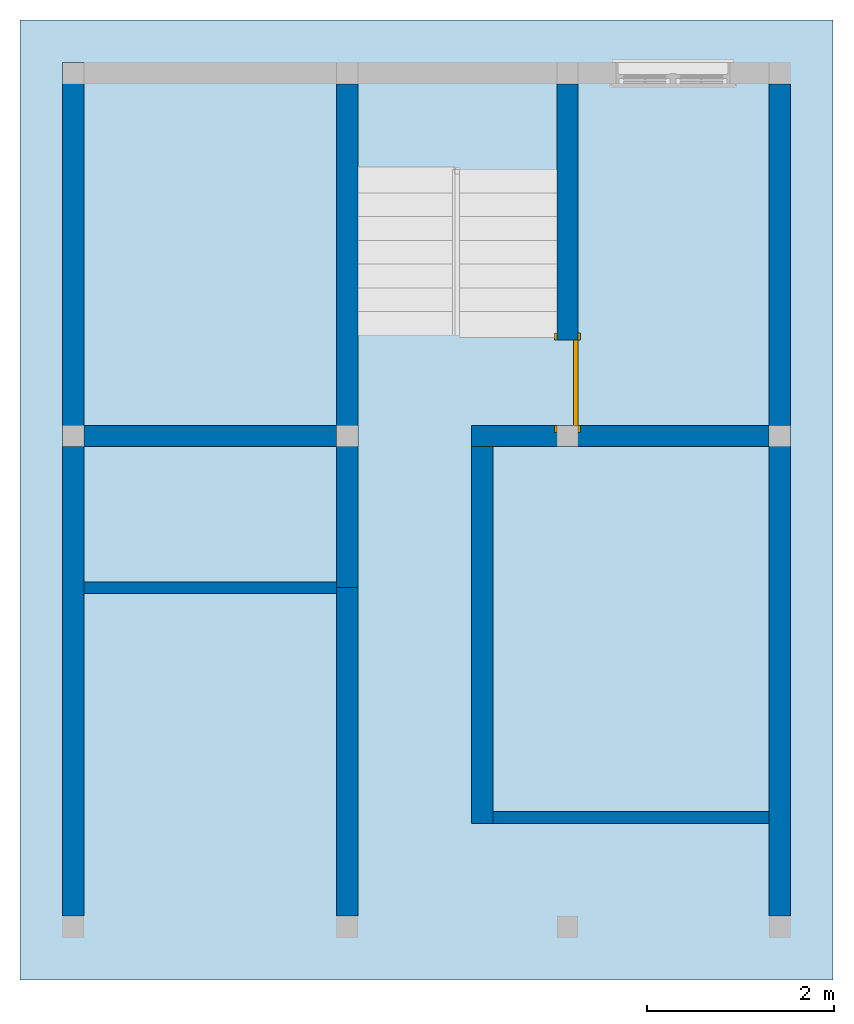
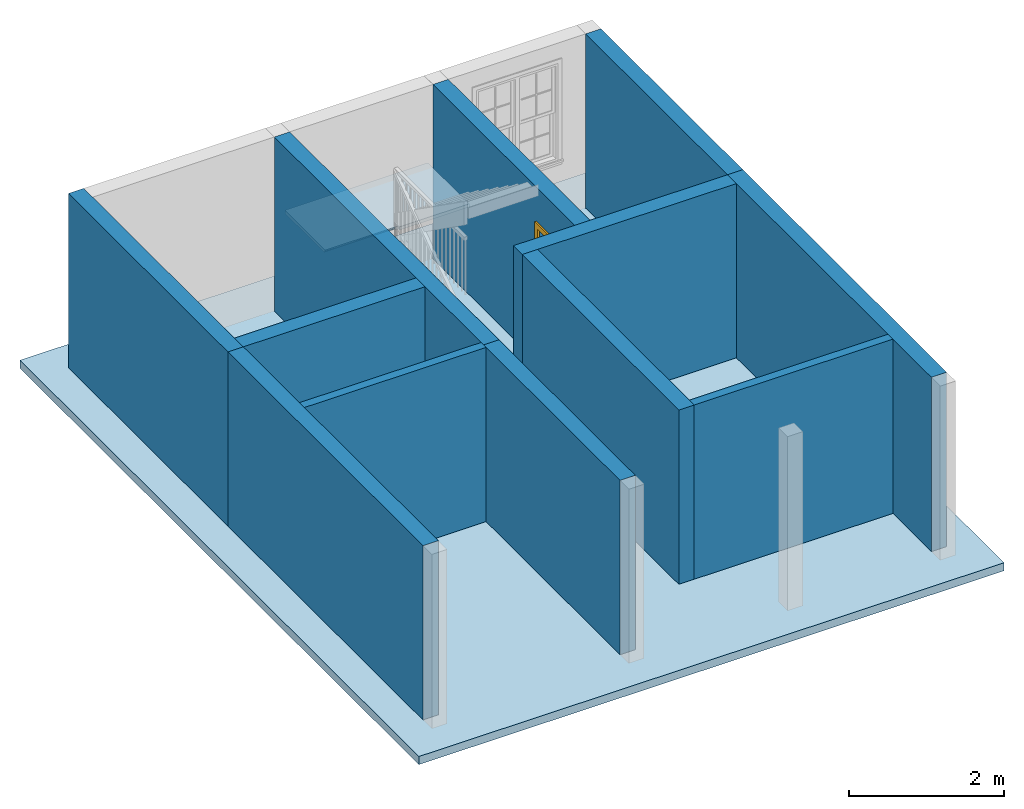
# One storey, part 2 of 6: 12 walls, 2 slabs, 1 door, 2 openings, 1 element without a shape of its own.
"""IFC2X3 building model written with IfcOpenShell, lengths in feet."""

from ifc_helpers import new_model, entity, si_unit, converted_unit, derived_unit, direction, frame, frame_2d, origin, origin_2d_with_axis, place, context, subcontext, project, spatial, polyline, rectangle, outline, extrude, clip, bounded_halfspace, faceted_brep, source, transform, mapped, material, material_list, layer, layer_set, layer_usage, type_object, type_shapes, element, fill, aggregate, save


model = new_model("IFC2X3")

# Units and contexts
model_context = context("Model", 3, precision=0.0001, world=origin(), true_north=direction((6.123031769111886e-17, 1.0)))
body_context = subcontext(model_context, "Body", "Model", "MODEL_VIEW")
ifc_project = project(units=[converted_unit("LENGTHUNIT", "FOOT", entity("IfcLengthMeasure", 0.3048), si_unit("LENGTHUNIT", "METRE"), dimensions=[1, 0, 0, 0, 0, 0, 0]), converted_unit("AREAUNIT", "SQUARE FOOT", entity("IfcAreaMeasure", 0.09290304), si_unit("AREAUNIT", "SQUARE_METRE"), dimensions=[2, 0, 0, 0, 0, 0, 0]), converted_unit("VOLUMEUNIT", "CUBIC FOOT", entity("IfcVolumeMeasure", 0.028316846592000004), si_unit("VOLUMEUNIT", "CUBIC_METRE"), dimensions=[3, 0, 0, 0, 0, 0, 0]), converted_unit("PLANEANGLEUNIT", "DEGREE", entity("IfcPlaneAngleMeasure", 0.017453292519943278), si_unit("PLANEANGLEUNIT", "RADIAN"), dimensions=[0, 0, 0, 0, 0, 0, 0]), si_unit("MASSUNIT", "GRAM", prefix="KILO"), derived_unit("MASSDENSITYUNIT", [(si_unit("MASSUNIT", "GRAM", prefix="KILO"), 1), (si_unit("LENGTHUNIT", "METRE"), -3)]), derived_unit("IONCONCENTRATIONUNIT", [(si_unit("MASSUNIT", "GRAM", prefix="KILO"), 1), (si_unit("LENGTHUNIT", "METRE"), -3)]), derived_unit("MOMENTOFINERTIAUNIT", [(si_unit("LENGTHUNIT", "METRE"), 4)]), si_unit("TIMEUNIT", "SECOND"), si_unit("FREQUENCYUNIT", "HERTZ"), si_unit("THERMODYNAMICTEMPERATUREUNIT", "DEGREE_CELSIUS"), derived_unit("THERMALTRANSMITTANCEUNIT", [(si_unit("MASSUNIT", "GRAM", prefix="KILO"), 1), (si_unit("THERMODYNAMICTEMPERATUREUNIT", "KELVIN"), -1), (si_unit("TIMEUNIT", "SECOND"), -3)]), derived_unit("THERMALCONDUCTANCEUNIT", [(si_unit("MASSUNIT", "GRAM", prefix="KILO"), 1), (si_unit("THERMODYNAMICTEMPERATUREUNIT", "KELVIN"), -1), (si_unit("TIMEUNIT", "SECOND"), -3), (si_unit("LENGTHUNIT", "METRE"), 1)]), derived_unit("VOLUMETRICFLOWRATEUNIT", [(si_unit("LENGTHUNIT", "METRE"), 3), (si_unit("TIMEUNIT", "SECOND"), -1)]), derived_unit("MASSFLOWRATEUNIT", [(si_unit("MASSUNIT", "GRAM", prefix="KILO"), 1), (si_unit("TIMEUNIT", "SECOND"), -1)]), derived_unit("ROTATIONALFREQUENCYUNIT", [(si_unit("TIMEUNIT", "SECOND"), -1)]), si_unit("ELECTRICCURRENTUNIT", "AMPERE"), si_unit("ELECTRICVOLTAGEUNIT", "VOLT"), si_unit("POWERUNIT", "WATT"), converted_unit("FORCEUNIT", "KIP", entity("IfcForceMeasure", 2.088543423315013e-05), si_unit("FORCEUNIT", "NEWTON"), dimensions=[1, 1, -2, 0, 0, 0, 0]), si_unit("ILLUMINANCEUNIT", "LUX"), si_unit("LUMINOUSFLUXUNIT", "LUMEN"), si_unit("LUMINOUSINTENSITYUNIT", "CANDELA"), si_unit("ENERGYUNIT", "JOULE"), derived_unit("USERDEFINED", [(si_unit("MASSUNIT", "GRAM", prefix="KILO"), -1), (si_unit("LENGTHUNIT", "METRE"), -2), (si_unit("TIMEUNIT", "SECOND"), 3), (si_unit("LUMINOUSFLUXUNIT", "LUMEN"), 1)]), derived_unit("USERDEFINED", [(si_unit("MASSUNIT", "GRAM", prefix="KILO"), 1), (si_unit("TIMEUNIT", "SECOND"), -3), (si_unit("LENGTHUNIT", "METRE"), 3), (si_unit("ELECTRICCURRENTUNIT", "AMPERE"), -2)]), derived_unit("SOUNDPOWERUNIT", [(si_unit("MASSUNIT", "GRAM", prefix="KILO"), 1), (si_unit("TIMEUNIT", "SECOND"), -3), (si_unit("LENGTHUNIT", "METRE"), 2)]), derived_unit("SOUNDPRESSUREUNIT", [(si_unit("MASSUNIT", "GRAM", prefix="KILO"), 1), (si_unit("LENGTHUNIT", "METRE"), -1), (si_unit("TIMEUNIT", "SECOND"), -2)]), derived_unit("LINEARVELOCITYUNIT", [(si_unit("LENGTHUNIT", "METRE"), 1), (si_unit("TIMEUNIT", "SECOND"), -1)]), si_unit("PRESSUREUNIT", "PASCAL"), derived_unit("USERDEFINED", [(si_unit("MASSUNIT", "GRAM", prefix="KILO"), 1), (si_unit("LENGTHUNIT", "METRE"), -2), (si_unit("TIMEUNIT", "SECOND"), -2)]), derived_unit("LINEARFORCEUNIT", [(si_unit("MASSUNIT", "GRAM", prefix="KILO"), 1), (si_unit("TIMEUNIT", "SECOND"), -2)]), derived_unit("PLANARFORCEUNIT", [(si_unit("MASSUNIT", "GRAM", prefix="KILO"), 1), (si_unit("LENGTHUNIT", "METRE"), -1), (si_unit("TIMEUNIT", "SECOND"), -2)]), derived_unit("SPECIFICHEATCAPACITYUNIT", [(si_unit("THERMODYNAMICTEMPERATUREUNIT", "KELVIN"), -1), (si_unit("LENGTHUNIT", "METRE"), 2), (si_unit("TIMEUNIT", "SECOND"), -2)]), derived_unit("HEATFLUXDENSITYUNIT", [(si_unit("MASSUNIT", "GRAM", prefix="KILO"), 1), (si_unit("TIMEUNIT", "SECOND"), -3)]), derived_unit("HEATINGVALUEUNIT", [(si_unit("LENGTHUNIT", "METRE"), 2), (si_unit("TIMEUNIT", "SECOND"), -2)]), derived_unit("VAPORPERMEABILITYUNIT", [(si_unit("LENGTHUNIT", "METRE"), -1), (si_unit("TIMEUNIT", "SECOND"), 1)]), derived_unit("DYNAMICVISCOSITYUNIT", [(si_unit("MASSUNIT", "GRAM", prefix="KILO"), 1), (si_unit("TIMEUNIT", "SECOND"), -1), (si_unit("LENGTHUNIT", "METRE"), -1)]), derived_unit("THERMALEXPANSIONCOEFFICIENTUNIT", [(si_unit("THERMODYNAMICTEMPERATUREUNIT", "KELVIN"), -1)]), derived_unit("MODULUSOFELASTICITYUNIT", [(si_unit("MASSUNIT", "GRAM", prefix="KILO"), 1), (si_unit("LENGTHUNIT", "METRE"), -1), (si_unit("TIMEUNIT", "SECOND"), -2)]), derived_unit("ISOTHERMALMOISTURECAPACITYUNIT", [(si_unit("LENGTHUNIT", "METRE"), 3), (si_unit("MASSUNIT", "GRAM", prefix="KILO"), -1)]), derived_unit("MOISTUREDIFFUSIVITYUNIT", [(si_unit("TIMEUNIT", "SECOND"), -1), (si_unit("LENGTHUNIT", "METRE"), 2)]), derived_unit("MASSPERLENGTHUNIT", [(si_unit("MASSUNIT", "GRAM", prefix="KILO"), 1), (si_unit("LENGTHUNIT", "METRE"), -1)]), derived_unit("THERMALRESISTANCEUNIT", [(si_unit("MASSUNIT", "GRAM", prefix="KILO"), -1), (si_unit("TIMEUNIT", "SECOND"), 3), (si_unit("THERMODYNAMICTEMPERATUREUNIT", "KELVIN"), 1)]), derived_unit("ACCELERATIONUNIT", [(si_unit("LENGTHUNIT", "METRE"), 1), (si_unit("TIMEUNIT", "SECOND"), -2)]), derived_unit("ANGULARVELOCITYUNIT", [(si_unit("TIMEUNIT", "SECOND"), -1), (si_unit("PLANEANGLEUNIT", "RADIAN"), 1)]), derived_unit("LINEARSTIFFNESSUNIT", [(si_unit("MASSUNIT", "GRAM", prefix="KILO"), 1), (si_unit("TIMEUNIT", "SECOND"), -2)]), derived_unit("WARPINGCONSTANTUNIT", [(si_unit("LENGTHUNIT", "METRE"), 6)]), derived_unit("LINEARMOMENTUNIT", [(si_unit("MASSUNIT", "GRAM", prefix="KILO"), 1), (si_unit("LENGTHUNIT", "METRE"), 1), (si_unit("TIMEUNIT", "SECOND"), -2)]), derived_unit("TORQUEUNIT", [(si_unit("MASSUNIT", "GRAM", prefix="KILO"), 1), (si_unit("LENGTHUNIT", "METRE"), 2), (si_unit("TIMEUNIT", "SECOND"), -2)])], contexts=[model_context])

# Site, building, storey
site_placement = place(None, origin())
site = spatial("IfcSite", under=ifc_project, at=site_placement, CompositionType="ELEMENT")
building_placement = place(site_placement, origin())
building = spatial("IfcBuilding", under=site, at=building_placement, CompositionType="ELEMENT")
storey_placement = place(building_placement, origin())
storey = spatial("IfcBuildingStorey", under=building, at=storey_placement, Name="Level 1", CompositionType="ELEMENT", Elevation=0.0)

# Slab
ifc_material_1 = material(Name="Clad - White")
ifc_layer_1 = layer(ifc_material_1, 0.4166666666666667)
ifc_layer_set_1 = layer_set([ifc_layer_1])
ifc_layer_usage_1 = layer_usage(ifc_layer_set_1, "AXIS3", "POSITIVE", 0.0)
slab_type_1 = type_object("IfcSlabType", PredefinedType="FLOOR", material=ifc_layer_set_1)
slab_1_placement = place(storey_placement, origin())
element("IfcSlab", 1, at=slab_1_placement, inside=storey, type_object=slab_type_1, material=ifc_layer_usage_1, PredefinedType="FLOOR", context=body_context, shape_type="SweptSolid", body=[
    extrude(rectangle(XDim=33.74999999999997, YDim=28.583333333333364, at=origin_2d_with_axis()), frame((-4.11824641858448, 1.3755802980716219, 0.0), z_axis=(0.0, 0.0, -1.0), x_axis=(0.0, 1.0, 0.0)), (0.0, 0.0, 1.0), 0.4166666666666667),
])

# Stair, slab
type_product = type_object("IfcTypeProduct")
stair_placement = place(storey_placement, origin())
stair = element("IfcStair", 2, at=stair_placement, inside=storey, type_object=type_product, Name="Assembled Stair:Stair", ShapeType="HALF_TURN_STAIR")
ifc_material_2 = material()
slab_type_2 = type_object("IfcSlabType", Name="Non-Monolithic Landing:Non-Monolithic Landing", PredefinedType="LANDING")
slab_2_placement = place(stair_placement, frame((-6.534913085251134, 12.917246964738318, 0.0)))
slab_2 = element("IfcSlab", 3, at=slab_2_placement, type_object=slab_type_2, material=ifc_material_2, Name="Assembled Stair:Stair:385185 Landing 1", ObjectType="Non-Monolithic Landing:Non-Monolithic Landing", PredefinedType="LANDING", context=body_context, shape_type="Brep", body=[
    faceted_brep([(0.0, 0.08333333333334636, 4.645833333334168), (0.0, 0.16666666666668029, 4.562500000000834), (3.416666666666666, 0.16666666666667318, 4.562500000000833), (3.416666666666666, 0.08333333333333925, 4.645833333334168), (3.583333333333333, 0.08333333333334281, 4.708333333334168), (3.583333333333333, 0.0, 4.708333333334168), (7.0, 0.0, 4.708333333334168), (7.0, 0.08333333333333748, 4.708333333334168), (7.0, 3.5, 4.708333333334168), (0.0, 3.500000000000014, 4.708333333334168), (0.0, 0.08333333333330373, 4.708333333334168), (3.416666666666666, 0.16666666666667318, 4.541666666667501), (0.0, 0.16666666666668029, 4.541666666667501), (0.0, 3.500000000000014, 4.541666666667501), (7.0, 3.5, 4.541666666667501), (7.0, 0.0833333333333357, 4.541666666667501), (7.0, 0.0, 4.541666666667501), (3.583333333333333, 0.0, 4.541666666667501), (3.583333333333333, 0.08333333333334103, 4.541666666667501), (3.416666666666666, 0.08333333333333925, 4.541666666667501)], [[[0, 1, 2, 3]], [[4, 5, 6, 7, 8, 9, 10]], [[11, 12, 13, 14, 15, 16, 17, 18, 19]], [[12, 11, 2, 1]], [[11, 19, 3, 2]], [[4, 10, 0, 3, 19, 18]], [[5, 4, 18, 17]], [[6, 5, 17, 16]], [[7, 6, 16, 15]], [[8, 7, 15, 14]], [[9, 8, 14, 13]], [[10, 9, 13, 12, 1, 0]]]),
])
aggregate(stair, [slab_2])

# Walls
ifc_material_3 = material(Name="Exterior Wall")
ifc_layer_2 = layer(ifc_material_3, 0.75)
ifc_layer_set_2 = layer_set([ifc_layer_2])
ifc_layer_usage_2 = layer_usage(ifc_layer_set_2, "AXIS2", "NEGATIVE", 0.37500000000000006)
wall_type_1 = type_object("IfcWallType", PredefinedType="STANDARD", material=ifc_layer_set_2)
wall_1_placement = place(storey_placement, frame((-16.534913085251162, 3.2505802980716396, 0.0), z_axis=(0.0, 0.0, 1.0), x_axis=(0.0, 1.0, 0.0)))
element("IfcWallStandardCase", 4, at=wall_1_placement, inside=storey, type_object=wall_type_1, material=ifc_layer_usage_2, context=body_context, shape_type="Clipping", body=[
    clip(extrude(rectangle(XDim=13.499999999999972, YDim=0.75, at=frame_2d((6.749999999999986, 0.0), x_axis=(-1.0, 0.0))), origin(), (0.0, 0.0, 1.0), 9.00000000000167), bounded_halfspace(frame((0.0, -0.375, 9.0), z_axis=(0.0, 0.0, -1.0), x_axis=(-1.0, 0.0, 0.0)), True, frame((0.0, -0.375, 9.0)), polyline([(0.0, 0.0), (0.75, 0.0), (12.749999999999968, 0.0), (13.499999999999968, 0.0), (13.499999999999968, 0.75), (0.0, 0.75), (0.0, 0.0)]))),
])
wall_2_placement = place(storey_placement, frame((-16.534913085251162, -13.24941970192836, 0.0), z_axis=(0.0, 0.0, 1.0), x_axis=(0.0, 1.0, 0.0)))
element("IfcWallStandardCase", 5, at=wall_2_placement, inside=storey, type_object=wall_type_1, material=ifc_layer_usage_2, context=body_context, shape_type="Clipping", body=[
    clip(extrude(rectangle(XDim=16.5, YDim=0.75, at=frame_2d((8.25, 0.0), x_axis=(-1.0, 0.0))), origin(), (0.0, 0.0, 1.0), 9.00000000000167), bounded_halfspace(frame((0.0, -0.375, 9.0), z_axis=(0.0, 0.0, -1.0), x_axis=(-1.0, 0.0, 0.0)), True, frame((0.0, -0.375, 9.0)), polyline([(0.0, 0.0), (11.333333333333275, 0.0), (11.749999999999943, 0.0), (16.5, 0.0), (16.5, 0.75), (0.0, 0.75), (0.0, 0.0)]))),
])
wall_3_placement = place(storey_placement, frame((8.29842024808221, 4.00058029807164, 0.0), z_axis=(0.0, 0.0, 1.0), x_axis=(0.0, -1.0, 0.0)))
element("IfcWallStandardCase", 6, at=wall_3_placement, inside=storey, type_object=wall_type_1, material=ifc_layer_usage_2, context=body_context, shape_type="Clipping", body=[
    clip(extrude(rectangle(XDim=17.250000000000398, YDim=0.75, at=frame_2d((8.625000000000199, 5.551115123125783e-17), x_axis=(-1.0, 0.0))), origin(), (0.0, 0.0, 1.0), 9.00000000000167), bounded_halfspace(frame((0.0, -0.3749999999999995, 9.0), z_axis=(0.0, 0.0, -1.0), x_axis=(1.0, 0.0, 0.0)), True, frame((0.0, -0.3749999999999995, 9.0)), polyline([(0.0, 0.0), (0.7500000000000013, 0.0), (13.583333333333334, 0.0), (14.0, 0.0), (17.250000000000398, 0.0), (17.250000000000398, 0.7500000000000001), (0.0, 0.75), (0.0, 0.0)]))),
])
wall_4_placement = place(storey_placement, frame((8.29842024808221, 16.000580298071668, 0.0), z_axis=(0.0, 0.0, 1.0), x_axis=(0.0, -1.0, 0.0)))
element("IfcWallStandardCase", 7, at=wall_4_placement, inside=storey, type_object=wall_type_1, material=ifc_layer_usage_2, context=body_context, shape_type="Clipping", body=[
    clip(extrude(rectangle(XDim=12.000000000000028, YDim=0.75, at=frame_2d((6.000000000000014, 0.0), x_axis=(-1.0, 0.0))), origin(), (0.0, 0.0, 1.0), 9.00000000000167), bounded_halfspace(frame((0.0, -0.375, 9.0), z_axis=(0.0, 0.0, -1.0), x_axis=(1.0, 0.0, 0.0)), True, frame((0.0, -0.375, 9.0)), polyline([(0.0, 0.0), (12.0, 0.0), (12.0, 0.75), (0.0, 0.75), (0.0, 0.0)]))),
])
wall_5_placement = place(storey_placement, frame((-6.9099130852510475, -1.7077530352617831, 0.0), z_axis=(0.0, 0.0, 1.0), x_axis=(0.0, 1.0, 0.0)))
element("IfcWallStandardCase", 8, at=wall_5_placement, inside=storey, type_object=wall_type_1, material=ifc_layer_usage_2, context=body_context, shape_type="Clipping", body=[
    clip(extrude(rectangle(XDim=17.708333333333417, YDim=0.75, at=frame_2d((8.854166666666709, -3.608224830031759e-16), x_axis=(-1.0, 0.0))), origin(), (0.0, 0.0, 1.0), 9.00000000000167), bounded_halfspace(frame((0.0, -0.3749999999999998, 9.0), z_axis=(0.0, 0.0, -1.0), x_axis=(-1.0, 0.0, 0.0)), True, frame((0.0, -0.3749999999999998, 9.0)), polyline([(0.0, 0.0), (8.875000000000103, 0.0), (17.708333333333414, 0.0), (17.708333333333417, 0.7499999999999993), (5.7083333333334245, 0.7500000000000001), (4.958333333333423, 0.7499999999999996), (0.20833333333333837, 0.7499999999999996), (0.0, 0.75), (0.0, 0.0)]))),
])

# Wall, opening, door
wall_6_placement = place(storey_placement, frame((0.8400869147488379, 16.000580298071654, 0.0), z_axis=(0.0, 0.0, 1.0), x_axis=(0.0, -1.0, 0.0)))
wall_6 = element("IfcWallStandardCase", 9, at=wall_6_placement, inside=storey, type_object=wall_type_1, material=ifc_layer_usage_2, context=body_context, shape_type="Clipping", body=[
    clip(extrude(rectangle(XDim=12.000000000000014, YDim=0.75, at=frame_2d((6.000000000000007, 0.0), x_axis=(-1.0, 0.0))), origin(), (0.0, 0.0, 1.0), 9.00000000000167), bounded_halfspace(frame((12.0, 0.375, 9.0), z_axis=(0.0, 0.0, -1.0), x_axis=(1.0, 0.0, 0.0)), True, frame((12.0, 0.375, 9.0)), polyline([(0.0, 0.0), (-12.0, 0.0), (-12.0, -0.75), (-3.166666666666684, -0.7500000000000001), (0.0, -0.7500000000000001), (0.0, 0.0)]))),
])
opening_1_placement = place(wall_6_placement, frame((9.0, -0.37500000000000294, 0.0)))
opening_1 = element("IfcOpeningElement", 10, at=opening_1_placement, cuts=wall_6, ObjectType="Opening", context=body_context, shape_type="SweptSolid", body=[
    extrude(rectangle(XDim=2.999999999999999, YDim=6.999999999999999, at=frame_2d((3.4999999999999996, 1.4999999999999993), x_axis=(0.0, 1.0))), frame((0.0, 0.0, 0.0), z_axis=(0.0, 1.0, 0.0), x_axis=(0.0, 0.0, 1.0)), (0.0, 0.0, 1.0), 0.7500000000000001),
])
ifc_material_4 = material(Name="Door - Frame")
ifc_material_5 = material(Name="Door - Panel")
ifc_material_list = material_list([ifc_material_4, ifc_material_5])
door_style = type_object("IfcDoorStyle", ConstructionType="NOTDEFINED", OperationType="SINGLE_SWING_RIGHT", ParameterTakesPrecedence=False, Sizeable=False, material=ifc_material_list)
shared_shape = source(origin(), body_context, "Body", "SweptSolid", [
    extrude(outline(polyline([(-1.7500000000000002, -3.687499999999997), (1.7499999999999993, -3.687499999999997), (1.7499999999999993, 3.5625000000000013), (1.4999999999999993, 3.5625000000000013), (1.4999999999999993, -3.4375000000000067), (-1.4999999999999984, -3.4375000000000067), (-1.4999999999999984, 3.5625000000000013), (-1.7500000000000002, 3.5625000000000013), (-1.7500000000000002, -3.687499999999997)])), frame((1.5000000000000016, 0.7499999999999973, 3.5625000000000013), z_axis=(0.0, 1.0, 0.0), x_axis=(1.0, 0.0, 0.0)), (0.0, 0.0, 1.0), 0.08333333333333331),
    extrude(outline(polyline([(-3.687499999999999, -1.749999999999991), (3.562499999999999, -1.749999999999991), (3.562499999999999, -1.5000000000000246), (-3.437499999999999, -1.5000000000000246), (-3.437499999999999, 1.5000000000000064), (3.562499999999999, 1.5000000000000064), (3.562499999999999, 1.7500000000000087), (-3.687499999999999, 1.7500000000000087), (-3.687499999999999, -1.749999999999991)])), frame((1.5000000000000102, -0.08333333333333603, 3.562499999999999), z_axis=(0.0, 1.0, 0.0), x_axis=(0.0, 0.0, -1.0)), (0.0, 0.0, 1.0), 0.08333333333333331),
    extrude(rectangle(XDim=0.16666666666666666, YDim=2.9999999999999996, at=frame_2d((-1.3877787807814457e-17, 0.0), x_axis=(1.0, 0.0))), frame((1.5000000000000009, 0.6666666666666641, 0.0), z_axis=(0.0, 0.0, 1.0), x_axis=(0.0, 1.0, 0.0)), (0.0, 0.0, 1.0), 6.999999999999998),
])
type_shapes(door_style, [shared_shape])
door_placement = place(opening_1_placement, origin())
door = element("IfcDoor", 11, at=door_placement, inside=storey, type_object=door_style, material=ifc_material_list, OverallHeight=6.999999999999999, OverallWidth=3.000000000000001, context=body_context, shape_type="MappedRepresentation", body=[
    mapped(shared_shape, transform((0.0, 0.0, 0.0), scale=1.0)),
])
fill(opening_1, door)

# Wall, opening
wall_7_placement = place(storey_placement, frame((-2.534913085251162, 3.6255802980716396, 0.0)))
wall_7 = element("IfcWallStandardCase", 12, at=wall_7_placement, inside=storey, type_object=wall_type_1, material=ifc_layer_usage_2, context=body_context, shape_type="Clipping", body=[
    clip(extrude(rectangle(XDim=10.458333333333371, YDim=0.75, at=frame_2d((5.229166666666686, 0.0), x_axis=(-1.0, 0.0))), origin(), (0.0, 0.0, 1.0), 9.00000000000167), bounded_halfspace(frame((0.0, -0.375, 9.0), z_axis=(0.0, 0.0, -1.0), x_axis=(0.0, -1.0, 0.0)), True, frame((0.0, -0.375, 9.0)), polyline([(0.0, 0.0), (0.7499999999999996, 0.0), (10.458333333333371, 0.0), (10.458333333333371, 0.75), (3.75, 0.75), (3.0, 0.75), (0.0, 0.75), (0.0, 0.0)]))),
])
opening_2_placement = place(wall_7_placement, origin())
element("IfcOpeningElement", 13, at=opening_2_placement, cuts=wall_7, ObjectType="Opening", context=body_context, shape_type="SweptSolid", body=[
    extrude(rectangle(XDim=6.999999999999999, YDim=0.75, at=frame_2d((-2.7755575615628914e-17, 0.0), x_axis=(0.0, 1.0))), frame((3.3750000000000053, 0.3750000000000018, 3.4999999999999996), z_axis=(0.0, 1.0, 0.0), x_axis=(1.0, 0.0, 0.0)), (0.0, 0.0, 1.0), 3.0),
])

# Walls
wall_8_placement = place(storey_placement, frame((-16.159913085251162, 3.6255802980716396, 0.0)))
element("IfcWallStandardCase", 14, at=wall_8_placement, inside=storey, type_object=wall_type_1, material=ifc_layer_usage_2, context=body_context, shape_type="Clipping", body=[
    clip(extrude(rectangle(XDim=8.875000000000083, YDim=0.75, at=frame_2d((4.437500000000042, 0.0), x_axis=(-1.0, 0.0))), origin(), (0.0, 0.0, 1.0), 9.00000000000167), bounded_halfspace(frame((0.0, -0.375, 9.0), z_axis=(0.0, 0.0, -1.0), x_axis=(0.0, -1.0, 0.0)), True, frame((0.0, -0.375, 9.0)), polyline([(0.0, 0.0), (8.875000000000083, 0.0), (8.875000000000078, 0.75), (0.0, 0.75), (0.0, 0.0)]))),
])
wall_9_placement = place(storey_placement, frame((-2.159913085251162, 3.2505802980716396, 0.0), z_axis=(0.0, 0.0, 1.0), x_axis=(0.0, -1.0, 0.0)))
element("IfcWallStandardCase", 15, at=wall_9_placement, inside=storey, type_object=wall_type_1, material=ifc_layer_usage_2, context=body_context, shape_type="Clipping", body=[
    clip(extrude(rectangle(XDim=13.249999999999968, YDim=0.75, at=frame_2d((6.624999999999984, 0.0), x_axis=(-1.0, 0.0))), origin(), (0.0, 0.0, 1.0), 9.00000000000167), bounded_halfspace(frame((0.0, -0.375, 9.0), z_axis=(0.0, 0.0, -1.0), x_axis=(1.0, 0.0, 0.0)), True, frame((0.0, -0.375, 9.0)), polyline([(0.0, 0.0), (13.249999999999966, 0.0), (13.249999999999968, 0.75), (12.833333333333302, 0.75), (0.0, 0.75), (0.0, 0.0)]))),
])
wall_10_placement = place(storey_placement, frame((-6.909913085251048, -1.7077530352617805, 0.0), z_axis=(0.0, 0.0, 1.0), x_axis=(0.0, -1.0, 0.0)))
element("IfcWallStandardCase", 16, at=wall_10_placement, inside=storey, type_object=wall_type_1, material=ifc_layer_usage_2, context=body_context, shape_type="Clipping", body=[
    clip(extrude(rectangle(XDim=11.541666666666579, YDim=0.75, at=frame_2d((5.7708333333332895, -1.6653345369377348e-16), x_axis=(-1.0, 0.0))), origin(), (0.0, 0.0, 1.0), 9.00000000000167), bounded_halfspace(frame((0.0, -0.37499999999999994, 9.0), z_axis=(0.0, 0.0, -1.0), x_axis=(1.0, 0.0, 0.0)), True, frame((0.0, -0.37499999999999994, 9.0)), polyline([(0.0, 0.0), (0.20833333333333215, 0.0), (11.541666666666579, 0.0), (11.541666666666579, 0.7499999999999997), (0.0, 0.75), (0.0, 0.0)]))),
])
ifc_layer_3 = layer(ifc_material_1, 0.4166666666666667)
ifc_layer_set_3 = layer_set([ifc_layer_3])
ifc_layer_usage_3 = layer_usage(ifc_layer_set_3, "AXIS2", "NEGATIVE", 0.20833333333333337)
wall_type_2 = type_object("IfcWallType", PredefinedType="STANDARD", material=ifc_layer_set_3)
wall_11_placement = place(storey_placement, frame((-16.159913085251162, -1.7077530352617507, 0.0)))
element("IfcWallStandardCase", 17, at=wall_11_placement, inside=storey, type_object=wall_type_2, material=ifc_layer_usage_3, context=body_context, shape_type="Clipping", body=[
    clip(extrude(rectangle(XDim=8.875000000000117, YDim=0.41666666666666696, at=frame_2d((4.437500000000059, 0.0), x_axis=(-1.0, 0.0))), origin(), (0.0, 0.0, 1.0), 9.00000000000167), bounded_halfspace(frame((0.0, -0.20833333333333326, 9.0), z_axis=(0.0, 0.0, -1.0), x_axis=(0.0, -1.0, 0.0)), True, frame((0.0, -0.20833333333333326, 9.0)), polyline([(0.0, 0.0), (8.875000000000117, 0.0), (8.875000000000114, 0.2083333333333286), (8.875000000000114, 0.4166666666666661), (0.0, 0.41666666666666674), (0.0, 0.0)]))),
])
wall_12_placement = place(storey_placement, frame((7.9234202480822065, -9.791086368595026, 0.0), z_axis=(0.0, 0.0, 1.0), x_axis=(-1.0, 0.0, 0.0)))
element("IfcWallStandardCase", 18, at=wall_12_placement, inside=storey, type_object=wall_type_2, material=ifc_layer_usage_3, context=body_context, shape_type="Clipping", body=[
    clip(extrude(rectangle(XDim=9.708333333333371, YDim=0.41666666666666785, at=frame_2d((4.854166666666686, -3.191891195797325e-16), x_axis=(-1.0, 0.0))), origin(), (0.0, 0.0, 1.0), 9.00000000000167), bounded_halfspace(frame((0.0, -0.20833333333333215, 9.0), z_axis=(0.0, 0.0, -1.0), x_axis=(0.0, 1.0, 0.0)), True, frame((0.0, -0.20833333333333215, 9.0)), polyline([(0.0, 0.0), (9.708333333333368, 0.0), (9.708333333333366, 0.4166666666666643), (0.0, 0.4166666666666661), (0.0, 0.0)]))),
])

save(model, "model.ifc")
